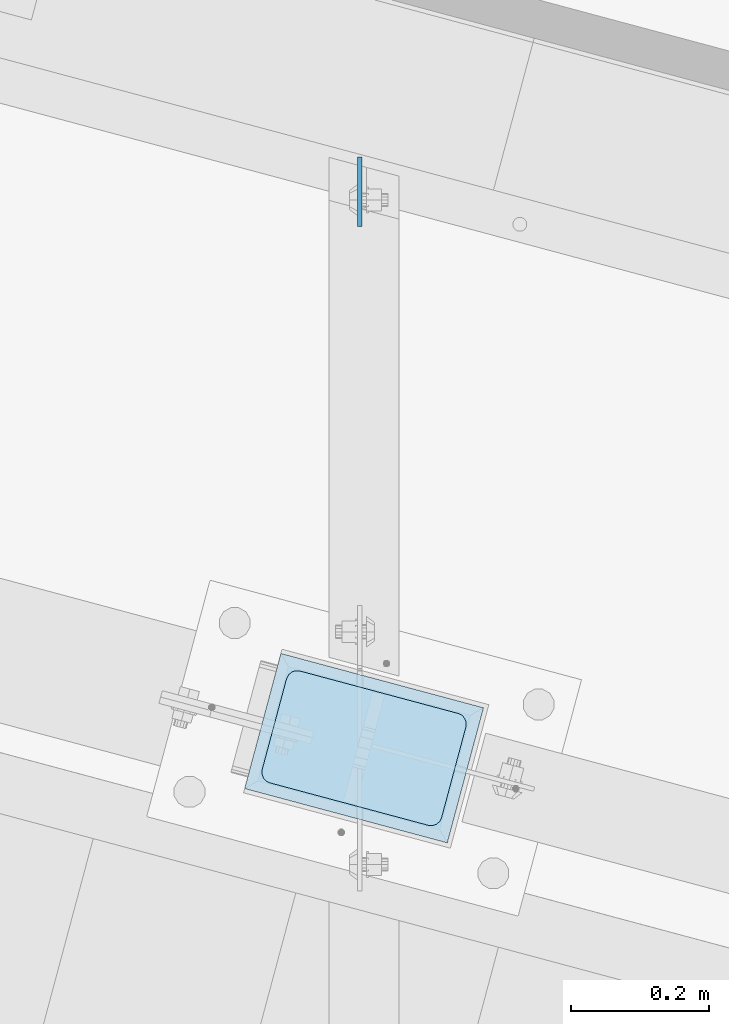
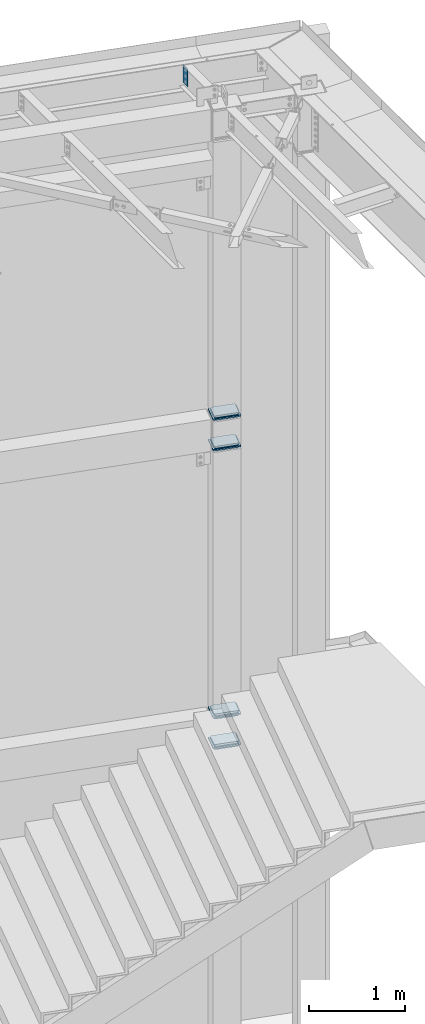
# One storey, part 1703 of 1763: 13 plates, 2 elements without a shape of their own.
"""IFC2X3 building model written with IfcOpenShell, lengths in millimetres."""

from ifc_helpers import new_model, si_unit, frame, origin_with_axes, place, context, subcontext, project, spatial, faceted_brep, material, type_object, element, aggregate, save


model = new_model("IFC2X3")

# Units and contexts
model_context = context("Model", 3, precision=1e-05, world=origin_with_axes())
body_context = subcontext(model_context, "Body", "Model", "MODEL_VIEW")
ifc_project = project(units=[si_unit("LENGTHUNIT", "METRE", prefix="MILLI"), si_unit("AREAUNIT", "SQUARE_METRE"), si_unit("VOLUMEUNIT", "CUBIC_METRE"), si_unit("MASSUNIT", "GRAM", prefix="KILO"), si_unit("TIMEUNIT", "SECOND"), si_unit("PLANEANGLEUNIT", "RADIAN"), si_unit("SOLIDANGLEUNIT", "STERADIAN"), si_unit("THERMODYNAMICTEMPERATUREUNIT", "DEGREE_CELSIUS"), si_unit("LUMINOUSINTENSITYUNIT", "LUMEN")], contexts=[model_context])

# Site, building, storey
site_placement = place(None, origin_with_axes())
site = spatial("IfcSite", under=ifc_project, at=site_placement, CompositionType="ELEMENT")
building_placement = place(site_placement, origin_with_axes())
building = spatial("IfcBuilding", under=site, at=building_placement, Name="Undefined", CompositionType="ELEMENT")
storey_placement = place(building_placement, origin_with_axes())
storey = spatial("IfcBuildingStorey", under=building, at=storey_placement, Name="Undefined", CompositionType="ELEMENT", Elevation=0.0)

# Assembly, plates
assembly_1_placement = place(storey_placement, origin_with_axes())
assembly_1 = element("IfcElementAssembly", 1, at=assembly_1_placement, inside=storey, Name="COLUMN", AssemblyPlace="NOTDEFINED", PredefinedType="RIGID_FRAME")
ifc_material_1 = material(Name="STEEL/A36")
plate_type_1 = type_object("IfcPlateType", PredefinedType="NOTDEFINED")
plate_1_placement = place(assembly_1_placement, frame((-22654.8919697089, 62208.7169412985, 8496.3), z_axis=(0.965913267114843, -0.258865912030785, 0.0), x_axis=(-0.258865912030778, -0.965913267114844, 3.00823476209188e-08)))
plate_1 = element("IfcPlate", 2, at=plate_1_placement, type_object=plate_type_1, material=ifc_material_1, Name="PLATE", context=body_context, shape_type="Brep", body=[
    faceted_brep([(-2.18278728425503e-11, -12.7000000000007, 15.875), (-1.67347025126219e-10, -12.7000000000007, 253.999999999985), (-1.67347025126219e-10, 12.7000000000007, 253.999999999985), (-2.18278728425503e-11, 12.7000000000007, 15.875), (1.20841242121242, -12.7000000000007, 260.075099488779), (1.20841242121242, 12.7000000000007, 260.075099488779), (4.649679848495, -12.7000000000007, 265.225320151323), (4.649679848495, 12.7000000000007, 265.225320151323), (9.79990051103232, -12.7000000000007, 268.666587578606), (9.79990051103232, 12.7000000000007, 268.666587578606), (15.8749999998181, -12.7000000000007, 269.874999999993), (15.8749999998181, 12.7000000000007, 269.874999999993), (152.400009155084, -12.7000000000007, 269.875000000073), (152.400009155084, 12.7000000000007, 269.875000000073), (158.475108643877, -12.7000000000007, 268.6665875787), (158.475108643877, 12.7000000000007, 268.6665875787), (163.625329306422, -12.7000000000007, 265.225320151425), (163.625329306422, 12.7000000000007, 265.225320151425), (167.066596733705, -12.7000000000007, 260.07509948888), (167.066596733705, 12.7000000000007, 260.07509948888), (168.275009155092, -12.7000000000007, 254.000000000087), (168.275009155092, 12.7000000000007, 254.000000000087), (168.275009155237, -12.7000000000007, 15.8750000001019), (168.275009155237, 12.7000000000007, 15.8750000001019), (167.066596733865, -12.7000000000007, 9.79990051130881), (167.066596733865, 12.7000000000007, 9.79990051130881), (163.625329306582, -12.7000000000007, 4.64967984876421), (163.625329306582, 12.7000000000007, 4.64967984876421), (158.475108644045, -12.7000000000007, 1.20841242148163), (158.475108644045, 12.7000000000007, 1.20841242148163), (152.400000000001, -12.6999998092651, 0.0), (152.400000000001, 12.6999998092651, 0.0), (15.8749999999854, -12.7000000000007, 0.0), (15.8749999999854, 12.7000000000007, 0.0), (9.79990051119239, -12.7000000000007, 1.20841242137976), (9.79990051119239, 12.7000000000007, 1.20841242137976), (4.64967984864779, -12.7000000000007, 4.64967984866234), (4.64967984864779, 12.7000000000007, 4.64967984866234), (1.20841242136521, -12.7000000000007, 9.79990051119967), (1.20841242136521, 12.7000000000007, 9.79990051119967)], [[[0, 1, 2, 3]], [[1, 4, 5, 2]], [[4, 6, 7, 5]], [[6, 8, 9, 7]], [[8, 10, 11, 9]], [[10, 12, 13, 11]], [[12, 14, 15, 13]], [[14, 16, 17, 15]], [[16, 18, 19, 17]], [[18, 20, 21, 19]], [[20, 22, 23, 21]], [[22, 24, 25, 23]], [[24, 26, 27, 25]], [[26, 28, 29, 27]], [[28, 30, 31, 29]], [[30, 32, 33, 31]], [[32, 34, 35, 33]], [[34, 36, 37, 35]], [[36, 38, 39, 37]], [[38, 0, 3, 39]], [[5, 7, 9, 11, 13, 15, 17, 19, 21, 23, 25, 27, 29, 31, 33, 35, 37, 39, 3, 2]], [[38, 36, 34, 32, 30, 28, 26, 24, 22, 20, 18, 16, 14, 12, 10, 8, 6, 4, 1, 0]]]),
])
plate_2_placement = place(assembly_1_placement, frame((-22654.8919697462, 62208.7169413085, 8455.025), z_axis=(0.965913267114843, -0.258865912030785, 0.0), x_axis=(-0.258865912030778, -0.965913267114844, 3.00823476209188e-08)))
plate_2 = element("IfcPlate", 3, at=plate_2_placement, type_object=plate_type_1, material=ifc_material_1, Name="PLATE", context=body_context, shape_type="Brep", body=[
    faceted_brep([(-2.18278728425503e-11, -12.7000000000007, 15.875), (-1.67347025126219e-10, -12.7000000000007, 253.999999999985), (-1.67347025126219e-10, 12.7000000000007, 253.999999999985), (-2.18278728425503e-11, 12.7000000000007, 15.875), (1.20841242121242, -12.7000000000007, 260.075099488779), (1.20841242121242, 12.7000000000007, 260.075099488779), (4.649679848495, -12.7000000000007, 265.225320151323), (4.649679848495, 12.7000000000007, 265.225320151323), (9.79990051103232, -12.7000000000007, 268.666587578606), (9.79990051103232, 12.7000000000007, 268.666587578606), (15.8749999998181, -12.7000000000007, 269.874999999993), (15.8749999998181, 12.7000000000007, 269.874999999993), (152.400009155084, -12.7000000000007, 269.875000000073), (152.400009155084, 12.7000000000007, 269.875000000073), (158.475108643877, -12.7000000000007, 268.6665875787), (158.475108643877, 12.7000000000007, 268.6665875787), (163.625329306422, -12.7000000000007, 265.225320151425), (163.625329306422, 12.7000000000007, 265.225320151425), (167.066596733705, -12.7000000000007, 260.07509948888), (167.066596733705, 12.7000000000007, 260.07509948888), (168.275009155092, -12.7000000000007, 254.000000000087), (168.275009155092, 12.7000000000007, 254.000000000087), (168.275009155237, -12.7000000000007, 15.8750000001019), (168.275009155237, 12.7000000000007, 15.8750000001019), (167.066596733865, -12.7000000000007, 9.79990051130881), (167.066596733865, 12.7000000000007, 9.79990051130881), (163.625329306582, -12.7000000000007, 4.64967984876421), (163.625329306582, 12.7000000000007, 4.64967984876421), (158.475108644045, -12.7000000000007, 1.20841242148163), (158.475108644045, 12.7000000000007, 1.20841242148163), (152.400000000001, -12.6999998092651, 0.0), (152.400000000001, 12.6999998092651, 0.0), (15.8749999999854, -12.7000000000007, 0.0), (15.8749999999854, 12.7000000000007, 0.0), (9.79990051119239, -12.7000000000007, 1.20841242137976), (9.79990051119239, 12.7000000000007, 1.20841242137976), (4.64967984864779, -12.7000000000007, 4.64967984866234), (4.64967984864779, 12.7000000000007, 4.64967984866234), (1.20841242136521, -12.7000000000007, 9.79990051119967), (1.20841242136521, 12.7000000000007, 9.79990051119967)], [[[0, 1, 2, 3]], [[1, 4, 5, 2]], [[4, 6, 7, 5]], [[6, 8, 9, 7]], [[8, 10, 11, 9]], [[10, 12, 13, 11]], [[12, 14, 15, 13]], [[14, 16, 17, 15]], [[16, 18, 19, 17]], [[18, 20, 21, 19]], [[20, 22, 23, 21]], [[22, 24, 25, 23]], [[24, 26, 27, 25]], [[26, 28, 29, 27]], [[28, 30, 31, 29]], [[30, 32, 33, 31]], [[32, 34, 35, 33]], [[34, 36, 37, 35]], [[36, 38, 39, 37]], [[38, 0, 3, 39]], [[5, 7, 9, 11, 13, 15, 17, 19, 21, 23, 25, 27, 29, 31, 33, 35, 37, 39, 3, 2]], [[38, 36, 34, 32, 30, 28, 26, 24, 22, 20, 18, 16, 14, 12, 10, 8, 6, 4, 1, 0]]]),
])
plate_3_placement = place(assembly_1_placement, frame((-22654.8919697834, 62208.7169413185, 8105.775), z_axis=(0.965913267114843, -0.258865912030785, 0.0), x_axis=(-0.258865912030778, -0.965913267114844, 3.00823476209188e-08)))
plate_3 = element("IfcPlate", 4, at=plate_3_placement, type_object=plate_type_1, material=ifc_material_1, Name="PLATE", context=body_context, shape_type="Brep", body=[
    faceted_brep([(-2.18278728425503e-11, -12.7000000000007, 15.875), (-1.67347025126219e-10, -12.7000000000007, 253.999999999985), (-1.67347025126219e-10, 12.7000000000007, 253.999999999985), (-2.18278728425503e-11, 12.7000000000007, 15.875), (1.20841242121242, -12.7000000000007, 260.075099488779), (1.20841242121242, 12.7000000000007, 260.075099488779), (4.649679848495, -12.7000000000007, 265.225320151323), (4.649679848495, 12.7000000000007, 265.225320151323), (9.79990051103232, -12.7000000000007, 268.666587578606), (9.79990051103232, 12.7000000000007, 268.666587578606), (15.8749999998181, -12.7000000000007, 269.874999999993), (15.8749999998181, 12.7000000000007, 269.874999999993), (152.400009155084, -12.7000000000007, 269.875000000073), (152.400009155084, 12.7000000000007, 269.875000000073), (158.475108643877, -12.7000000000007, 268.6665875787), (158.475108643877, 12.7000000000007, 268.6665875787), (163.625329306422, -12.7000000000007, 265.225320151425), (163.625329306422, 12.7000000000007, 265.225320151425), (167.066596733705, -12.7000000000007, 260.07509948888), (167.066596733705, 12.7000000000007, 260.07509948888), (168.275009155092, -12.7000000000007, 254.000000000087), (168.275009155092, 12.7000000000007, 254.000000000087), (168.275009155237, -12.7000000000007, 15.8750000001019), (168.275009155237, 12.7000000000007, 15.8750000001019), (167.066596733865, -12.7000000000007, 9.79990051130881), (167.066596733865, 12.7000000000007, 9.79990051130881), (163.625329306582, -12.7000000000007, 4.64967984876421), (163.625329306582, 12.7000000000007, 4.64967984876421), (158.475108644045, -12.7000000000007, 1.20841242148163), (158.475108644045, 12.7000000000007, 1.20841242148163), (152.400000000001, -12.6999998092651, 0.0), (152.400000000001, 12.6999998092651, 0.0), (15.8749999999854, -12.7000000000007, 0.0), (15.8749999999854, 12.7000000000007, 0.0), (9.79990051119239, -12.7000000000007, 1.20841242137976), (9.79990051119239, 12.7000000000007, 1.20841242137976), (4.64967984864779, -12.7000000000007, 4.64967984866234), (4.64967984864779, 12.7000000000007, 4.64967984866234), (1.20841242136521, -12.7000000000007, 9.79990051119967), (1.20841242136521, 12.7000000000007, 9.79990051119967)], [[[0, 1, 2, 3]], [[1, 4, 5, 2]], [[4, 6, 7, 5]], [[6, 8, 9, 7]], [[8, 10, 11, 9]], [[10, 12, 13, 11]], [[12, 14, 15, 13]], [[14, 16, 17, 15]], [[16, 18, 19, 17]], [[18, 20, 21, 19]], [[20, 22, 23, 21]], [[22, 24, 25, 23]], [[24, 26, 27, 25]], [[26, 28, 29, 27]], [[28, 30, 31, 29]], [[30, 32, 33, 31]], [[32, 34, 35, 33]], [[34, 36, 37, 35]], [[36, 38, 39, 37]], [[38, 0, 3, 39]], [[5, 7, 9, 11, 13, 15, 17, 19, 21, 23, 25, 27, 29, 31, 33, 35, 37, 39, 3, 2]], [[38, 36, 34, 32, 30, 28, 26, 24, 22, 20, 18, 16, 14, 12, 10, 8, 6, 4, 1, 0]]]),
])
plate_4_placement = place(assembly_1_placement, frame((-22654.8919698207, 62208.7169413285, 8064.5), z_axis=(0.965913267114843, -0.258865912030785, 0.0), x_axis=(-0.258865912030778, -0.965913267114844, 3.00823476209188e-08)))
plate_4 = element("IfcPlate", 5, at=plate_4_placement, type_object=plate_type_1, material=ifc_material_1, Name="PLATE", context=body_context, shape_type="Brep", body=[
    faceted_brep([(-2.18278728425503e-11, -12.7000000000007, 15.875), (-1.67347025126219e-10, -12.7000000000007, 253.999999999985), (-1.67347025126219e-10, 12.7000000000007, 253.999999999985), (-2.18278728425503e-11, 12.7000000000007, 15.875), (1.20841242121242, -12.7000000000007, 260.075099488779), (1.20841242121242, 12.7000000000007, 260.075099488779), (4.649679848495, -12.7000000000007, 265.225320151323), (4.649679848495, 12.7000000000007, 265.225320151323), (9.79990051103232, -12.7000000000007, 268.666587578606), (9.79990051103232, 12.7000000000007, 268.666587578606), (15.8749999998181, -12.7000000000007, 269.874999999993), (15.8749999998181, 12.7000000000007, 269.874999999993), (152.400009155084, -12.7000000000007, 269.875000000073), (152.400009155084, 12.7000000000007, 269.875000000073), (158.475108643877, -12.7000000000007, 268.6665875787), (158.475108643877, 12.7000000000007, 268.6665875787), (163.625329306422, -12.7000000000007, 265.225320151425), (163.625329306422, 12.7000000000007, 265.225320151425), (167.066596733705, -12.7000000000007, 260.07509948888), (167.066596733705, 12.7000000000007, 260.07509948888), (168.275009155092, -12.7000000000007, 254.000000000087), (168.275009155092, 12.7000000000007, 254.000000000087), (168.275009155237, -12.7000000000007, 15.8750000001019), (168.275009155237, 12.7000000000007, 15.8750000001019), (167.066596733865, -12.7000000000007, 9.79990051130881), (167.066596733865, 12.7000000000007, 9.79990051130881), (163.625329306582, -12.7000000000007, 4.64967984876421), (163.625329306582, 12.7000000000007, 4.64967984876421), (158.475108644045, -12.7000000000007, 1.20841242148163), (158.475108644045, 12.7000000000007, 1.20841242148163), (152.400000000001, -12.6999998092651, 0.0), (152.400000000001, 12.6999998092651, 0.0), (15.8749999999854, -12.7000000000007, 0.0), (15.8749999999854, 12.7000000000007, 0.0), (9.79990051119239, -12.7000000000007, 1.20841242137976), (9.79990051119239, 12.7000000000007, 1.20841242137976), (4.64967984864779, -12.7000000000007, 4.64967984866234), (4.64967984864779, 12.7000000000007, 4.64967984866234), (1.20841242136521, -12.7000000000007, 9.79990051119967), (1.20841242136521, 12.7000000000007, 9.79990051119967)], [[[0, 1, 2, 3]], [[1, 4, 5, 2]], [[4, 6, 7, 5]], [[6, 8, 9, 7]], [[8, 10, 11, 9]], [[10, 12, 13, 11]], [[12, 14, 15, 13]], [[14, 16, 17, 15]], [[16, 18, 19, 17]], [[18, 20, 21, 19]], [[20, 22, 23, 21]], [[22, 24, 25, 23]], [[24, 26, 27, 25]], [[26, 28, 29, 27]], [[28, 30, 31, 29]], [[30, 32, 33, 31]], [[32, 34, 35, 33]], [[34, 36, 37, 35]], [[36, 38, 39, 37]], [[38, 0, 3, 39]], [[5, 7, 9, 11, 13, 15, 17, 19, 21, 23, 25, 27, 29, 31, 33, 35, 37, 39, 3, 2]], [[38, 36, 34, 32, 30, 28, 26, 24, 22, 20, 18, 16, 14, 12, 10, 8, 6, 4, 1, 0]]]),
])
plate_5_placement = place(assembly_1_placement, frame((-22654.8919697089, 62208.7169412985, 4686.3), z_axis=(0.965913267114843, -0.258865912030785, 0.0), x_axis=(-0.258865912030778, -0.965913267114844, 3.00823476209188e-08)))
plate_5 = element("IfcPlate", 6, at=plate_5_placement, type_object=plate_type_1, material=ifc_material_1, Name="PLATE", context=body_context, shape_type="Brep", body=[
    faceted_brep([(-2.18278728425503e-11, -12.7000000000007, 15.875), (-1.67347025126219e-10, -12.7000000000007, 253.999999999985), (-1.67347025126219e-10, 12.7000000000007, 253.999999999985), (-2.18278728425503e-11, 12.7000000000007, 15.875), (1.20841242121242, -12.7000000000007, 260.075099488779), (1.20841242121242, 12.7000000000007, 260.075099488779), (4.649679848495, -12.7000000000007, 265.225320151323), (4.649679848495, 12.7000000000007, 265.225320151323), (9.79990051103232, -12.7000000000007, 268.666587578606), (9.79990051103232, 12.7000000000007, 268.666587578606), (15.8749999998181, -12.7000000000007, 269.874999999993), (15.8749999998181, 12.7000000000007, 269.874999999993), (152.400009155084, -12.7000000000007, 269.875000000073), (152.400009155084, 12.7000000000007, 269.875000000073), (158.475108643877, -12.7000000000007, 268.6665875787), (158.475108643877, 12.7000000000007, 268.6665875787), (163.625329306422, -12.7000000000007, 265.225320151425), (163.625329306422, 12.7000000000007, 265.225320151425), (167.066596733705, -12.7000000000007, 260.07509948888), (167.066596733705, 12.7000000000007, 260.07509948888), (168.275009155092, -12.7000000000007, 254.000000000087), (168.275009155092, 12.7000000000007, 254.000000000087), (168.275009155237, -12.7000000000007, 15.8750000001019), (168.275009155237, 12.7000000000007, 15.8750000001019), (167.066596733865, -12.7000000000007, 9.79990051130881), (167.066596733865, 12.7000000000007, 9.79990051130881), (163.625329306582, -12.7000000000007, 4.64967984876421), (163.625329306582, 12.7000000000007, 4.64967984876421), (158.475108644045, -12.7000000000007, 1.20841242148163), (158.475108644045, 12.7000000000007, 1.20841242148163), (152.400000000001, -12.6999998092651, 0.0), (152.400000000001, 12.6999998092651, 0.0), (15.8749999999854, -12.7000000000007, 0.0), (15.8749999999854, 12.7000000000007, 0.0), (9.79990051119239, -12.7000000000007, 1.20841242137976), (9.79990051119239, 12.7000000000007, 1.20841242137976), (4.64967984864779, -12.7000000000007, 4.64967984866234), (4.64967984864779, 12.7000000000007, 4.64967984866234), (1.20841242136521, -12.7000000000007, 9.79990051119967), (1.20841242136521, 12.7000000000007, 9.79990051119967)], [[[0, 1, 2, 3]], [[1, 4, 5, 2]], [[4, 6, 7, 5]], [[6, 8, 9, 7]], [[8, 10, 11, 9]], [[10, 12, 13, 11]], [[12, 14, 15, 13]], [[14, 16, 17, 15]], [[16, 18, 19, 17]], [[18, 20, 21, 19]], [[20, 22, 23, 21]], [[22, 24, 25, 23]], [[24, 26, 27, 25]], [[26, 28, 29, 27]], [[28, 30, 31, 29]], [[30, 32, 33, 31]], [[32, 34, 35, 33]], [[34, 36, 37, 35]], [[36, 38, 39, 37]], [[38, 0, 3, 39]], [[5, 7, 9, 11, 13, 15, 17, 19, 21, 23, 25, 27, 29, 31, 33, 35, 37, 39, 3, 2]], [[38, 36, 34, 32, 30, 28, 26, 24, 22, 20, 18, 16, 14, 12, 10, 8, 6, 4, 1, 0]]]),
])
plate_6_placement = place(assembly_1_placement, frame((-22654.8919697462, 62208.7169413085, 4645.025), z_axis=(0.965913267114843, -0.258865912030785, 0.0), x_axis=(-0.258865912030778, -0.965913267114844, 3.00823476209188e-08)))
plate_6 = element("IfcPlate", 7, at=plate_6_placement, type_object=plate_type_1, material=ifc_material_1, Name="PLATE", context=body_context, shape_type="Brep", body=[
    faceted_brep([(-2.18278728425503e-11, -12.7000000000007, 15.875), (-1.67347025126219e-10, -12.7000000000007, 253.999999999985), (-1.67347025126219e-10, 12.7000000000007, 253.999999999985), (-2.18278728425503e-11, 12.7000000000007, 15.875), (1.20841242121242, -12.7000000000007, 260.075099488779), (1.20841242121242, 12.7000000000007, 260.075099488779), (4.649679848495, -12.7000000000007, 265.225320151323), (4.649679848495, 12.7000000000007, 265.225320151323), (9.79990051103232, -12.7000000000007, 268.666587578606), (9.79990051103232, 12.7000000000007, 268.666587578606), (15.8749999998181, -12.7000000000007, 269.874999999993), (15.8749999998181, 12.7000000000007, 269.874999999993), (152.400009155084, -12.7000000000007, 269.875000000073), (152.400009155084, 12.7000000000007, 269.875000000073), (158.475108643877, -12.7000000000007, 268.6665875787), (158.475108643877, 12.7000000000007, 268.6665875787), (163.625329306422, -12.7000000000007, 265.225320151425), (163.625329306422, 12.7000000000007, 265.225320151425), (167.066596733705, -12.7000000000007, 260.07509948888), (167.066596733705, 12.7000000000007, 260.07509948888), (168.275009155092, -12.7000000000007, 254.000000000087), (168.275009155092, 12.7000000000007, 254.000000000087), (168.275009155237, -12.7000000000007, 15.8750000001019), (168.275009155237, 12.7000000000007, 15.8750000001019), (167.066596733865, -12.7000000000007, 9.79990051130881), (167.066596733865, 12.7000000000007, 9.79990051130881), (163.625329306582, -12.7000000000007, 4.64967984876421), (163.625329306582, 12.7000000000007, 4.64967984876421), (158.475108644045, -12.7000000000007, 1.20841242148163), (158.475108644045, 12.7000000000007, 1.20841242148163), (152.400000000001, -12.6999998092651, 0.0), (152.400000000001, 12.6999998092651, 0.0), (15.8749999999854, -12.7000000000007, 0.0), (15.8749999999854, 12.7000000000007, 0.0), (9.79990051119239, -12.7000000000007, 1.20841242137976), (9.79990051119239, 12.7000000000007, 1.20841242137976), (4.64967984864779, -12.7000000000007, 4.64967984866234), (4.64967984864779, 12.7000000000007, 4.64967984866234), (1.20841242136521, -12.7000000000007, 9.79990051119967), (1.20841242136521, 12.7000000000007, 9.79990051119967)], [[[0, 1, 2, 3]], [[1, 4, 5, 2]], [[4, 6, 7, 5]], [[6, 8, 9, 7]], [[8, 10, 11, 9]], [[10, 12, 13, 11]], [[12, 14, 15, 13]], [[14, 16, 17, 15]], [[16, 18, 19, 17]], [[18, 20, 21, 19]], [[20, 22, 23, 21]], [[22, 24, 25, 23]], [[24, 26, 27, 25]], [[26, 28, 29, 27]], [[28, 30, 31, 29]], [[30, 32, 33, 31]], [[32, 34, 35, 33]], [[34, 36, 37, 35]], [[36, 38, 39, 37]], [[38, 0, 3, 39]], [[5, 7, 9, 11, 13, 15, 17, 19, 21, 23, 25, 27, 29, 31, 33, 35, 37, 39, 3, 2]], [[38, 36, 34, 32, 30, 28, 26, 24, 22, 20, 18, 16, 14, 12, 10, 8, 6, 4, 1, 0]]]),
])
plate_7_placement = place(assembly_1_placement, frame((-22654.8919697834, 62208.7169413185, 4295.775), z_axis=(0.965913267114843, -0.258865912030785, 0.0), x_axis=(-0.258865912030778, -0.965913267114844, 3.00823476209188e-08)))
plate_7 = element("IfcPlate", 8, at=plate_7_placement, type_object=plate_type_1, material=ifc_material_1, Name="PLATE", context=body_context, shape_type="Brep", body=[
    faceted_brep([(-2.18278728425503e-11, -12.7000000000007, 15.875), (-1.67347025126219e-10, -12.7000000000007, 253.999999999985), (-1.67347025126219e-10, 12.7000000000007, 253.999999999985), (-2.18278728425503e-11, 12.7000000000007, 15.875), (1.20841242121242, -12.7000000000007, 260.075099488779), (1.20841242121242, 12.7000000000007, 260.075099488779), (4.649679848495, -12.7000000000007, 265.225320151323), (4.649679848495, 12.7000000000007, 265.225320151323), (9.79990051103232, -12.7000000000007, 268.666587578606), (9.79990051103232, 12.7000000000007, 268.666587578606), (15.8749999998181, -12.7000000000007, 269.874999999993), (15.8749999998181, 12.7000000000007, 269.874999999993), (152.400009155084, -12.7000000000007, 269.875000000073), (152.400009155084, 12.7000000000007, 269.875000000073), (158.475108643877, -12.7000000000007, 268.6665875787), (158.475108643877, 12.7000000000007, 268.6665875787), (163.625329306422, -12.7000000000007, 265.225320151425), (163.625329306422, 12.7000000000007, 265.225320151425), (167.066596733705, -12.7000000000007, 260.07509948888), (167.066596733705, 12.7000000000007, 260.07509948888), (168.275009155092, -12.7000000000007, 254.000000000087), (168.275009155092, 12.7000000000007, 254.000000000087), (168.275009155237, -12.7000000000007, 15.8750000001019), (168.275009155237, 12.7000000000007, 15.8750000001019), (167.066596733865, -12.7000000000007, 9.79990051130881), (167.066596733865, 12.7000000000007, 9.79990051130881), (163.625329306582, -12.7000000000007, 4.64967984876421), (163.625329306582, 12.7000000000007, 4.64967984876421), (158.475108644045, -12.7000000000007, 1.20841242148163), (158.475108644045, 12.7000000000007, 1.20841242148163), (152.400000000001, -12.6999998092651, 0.0), (152.400000000001, 12.6999998092651, 0.0), (15.8749999999854, -12.7000000000007, 0.0), (15.8749999999854, 12.7000000000007, 0.0), (9.79990051119239, -12.7000000000007, 1.20841242137976), (9.79990051119239, 12.7000000000007, 1.20841242137976), (4.64967984864779, -12.7000000000007, 4.64967984866234), (4.64967984864779, 12.7000000000007, 4.64967984866234), (1.20841242136521, -12.7000000000007, 9.79990051119967), (1.20841242136521, 12.7000000000007, 9.79990051119967)], [[[0, 1, 2, 3]], [[1, 4, 5, 2]], [[4, 6, 7, 5]], [[6, 8, 9, 7]], [[8, 10, 11, 9]], [[10, 12, 13, 11]], [[12, 14, 15, 13]], [[14, 16, 17, 15]], [[16, 18, 19, 17]], [[18, 20, 21, 19]], [[20, 22, 23, 21]], [[22, 24, 25, 23]], [[24, 26, 27, 25]], [[26, 28, 29, 27]], [[28, 30, 31, 29]], [[30, 32, 33, 31]], [[32, 34, 35, 33]], [[34, 36, 37, 35]], [[36, 38, 39, 37]], [[38, 0, 3, 39]], [[5, 7, 9, 11, 13, 15, 17, 19, 21, 23, 25, 27, 29, 31, 33, 35, 37, 39, 3, 2]], [[38, 36, 34, 32, 30, 28, 26, 24, 22, 20, 18, 16, 14, 12, 10, 8, 6, 4, 1, 0]]]),
])
plate_8_placement = place(assembly_1_placement, frame((-22654.8919698207, 62208.7169413285, 4254.5), z_axis=(0.965913267114843, -0.258865912030785, 0.0), x_axis=(-0.258865912030778, -0.965913267114844, 3.00823476209188e-08)))
plate_8 = element("IfcPlate", 9, at=plate_8_placement, type_object=plate_type_1, material=ifc_material_1, Name="PLATE", context=body_context, shape_type="Brep", body=[
    faceted_brep([(-2.18278728425503e-11, -12.7000000000007, 15.875), (-1.67347025126219e-10, -12.7000000000007, 253.999999999985), (-1.67347025126219e-10, 12.7000000000007, 253.999999999985), (-2.18278728425503e-11, 12.7000000000007, 15.875), (1.20841242121242, -12.7000000000007, 260.075099488779), (1.20841242121242, 12.7000000000007, 260.075099488779), (4.649679848495, -12.7000000000007, 265.225320151323), (4.649679848495, 12.7000000000007, 265.225320151323), (9.79990051103232, -12.7000000000007, 268.666587578606), (9.79990051103232, 12.7000000000007, 268.666587578606), (15.8749999998181, -12.7000000000007, 269.874999999993), (15.8749999998181, 12.7000000000007, 269.874999999993), (152.400009155084, -12.7000000000007, 269.875000000073), (152.400009155084, 12.7000000000007, 269.875000000073), (158.475108643877, -12.7000000000007, 268.6665875787), (158.475108643877, 12.7000000000007, 268.6665875787), (163.625329306422, -12.7000000000007, 265.225320151425), (163.625329306422, 12.7000000000007, 265.225320151425), (167.066596733705, -12.7000000000007, 260.07509948888), (167.066596733705, 12.7000000000007, 260.07509948888), (168.275009155092, -12.7000000000007, 254.000000000087), (168.275009155092, 12.7000000000007, 254.000000000087), (168.275009155237, -12.7000000000007, 15.8750000001019), (168.275009155237, 12.7000000000007, 15.8750000001019), (167.066596733865, -12.7000000000007, 9.79990051130881), (167.066596733865, 12.7000000000007, 9.79990051130881), (163.625329306582, -12.7000000000007, 4.64967984876421), (163.625329306582, 12.7000000000007, 4.64967984876421), (158.475108644045, -12.7000000000007, 1.20841242148163), (158.475108644045, 12.7000000000007, 1.20841242148163), (152.400000000001, -12.6999998092651, 0.0), (152.400000000001, 12.6999998092651, 0.0), (15.8749999999854, -12.7000000000007, 0.0), (15.8749999999854, 12.7000000000007, 0.0), (9.79990051119239, -12.7000000000007, 1.20841242137976), (9.79990051119239, 12.7000000000007, 1.20841242137976), (4.64967984864779, -12.7000000000007, 4.64967984866234), (4.64967984864779, 12.7000000000007, 4.64967984866234), (1.20841242136521, -12.7000000000007, 9.79990051119967), (1.20841242136521, 12.7000000000007, 9.79990051119967)], [[[0, 1, 2, 3]], [[1, 4, 5, 2]], [[4, 6, 7, 5]], [[6, 8, 9, 7]], [[8, 10, 11, 9]], [[10, 12, 13, 11]], [[12, 14, 15, 13]], [[14, 16, 17, 15]], [[16, 18, 19, 17]], [[18, 20, 21, 19]], [[20, 22, 23, 21]], [[22, 24, 25, 23]], [[24, 26, 27, 25]], [[26, 28, 29, 27]], [[28, 30, 31, 29]], [[30, 32, 33, 31]], [[32, 34, 35, 33]], [[34, 36, 37, 35]], [[36, 38, 39, 37]], [[38, 0, 3, 39]], [[5, 7, 9, 11, 13, 15, 17, 19, 21, 23, 25, 27, 29, 31, 33, 35, 37, 39, 3, 2]], [[38, 36, 34, 32, 30, 28, 26, 24, 22, 20, 18, 16, 14, 12, 10, 8, 6, 4, 1, 0]]]),
])
ifc_material_2 = material(Name="STEEL/A572-50")
plate_type_2 = type_object("IfcPlateType", PredefinedType="NOTDEFINED")
plate_9_placement = place(assembly_1_placement, frame((-22667.2292549365, 62230.1020943703, 8475.6625), z_axis=(0.965913267114843, -0.258865912030785, 0.0), x_axis=(-0.258865912030778, -0.965913267114844, 3.00823476209188e-08)))
plate_9 = element("IfcPlate", 10, at=plate_9_placement, type_object=plate_type_2, material=ifc_material_2, Name="PLATE", context=body_context, shape_type="Brep", body=[
    faceted_brep([(-7.27595761418343e-12, -7.9375, 0.0), (-1.96450855582952e-10, -7.9375, 304.799987792954), (-1.96450855582952e-10, 7.9375, 304.799987792954), (-7.27595761418343e-12, 7.9375, 0.0), (203.199996948031, -7.9375, 304.799987793078), (203.199996948031, 7.9375, 304.799987793078), (203.199996948228, -7.9375, 1.30967237055302e-10), (203.199996948228, 7.9375, 1.30967237055302e-10)], [[[0, 1, 2, 3]], [[1, 4, 5, 2]], [[4, 6, 7, 5]], [[6, 0, 3, 7]], [[5, 7, 3, 2]], [[6, 4, 1, 0]]]),
])
plate_10_placement = place(assembly_1_placement, frame((-22667.229255011, 62230.1020943903, 8085.1375), z_axis=(0.965913267114843, -0.258865912030785, 0.0), x_axis=(-0.258865912030778, -0.965913267114844, 3.00823476209188e-08)))
plate_10 = element("IfcPlate", 11, at=plate_10_placement, type_object=plate_type_2, material=ifc_material_2, Name="PLATE", context=body_context, shape_type="Brep", body=[
    faceted_brep([(-7.27595761418343e-12, -7.9375, 0.0), (-1.96450855582952e-10, -7.9375, 304.799987792954), (-1.96450855582952e-10, 7.9375, 304.799987792954), (-7.27595761418343e-12, 7.9375, 0.0), (203.199996948031, -7.9375, 304.799987793078), (203.199996948031, 7.9375, 304.799987793078), (203.199996948228, -7.9375, 1.30967237055302e-10), (203.199996948228, 7.9375, 1.30967237055302e-10)], [[[0, 1, 2, 3]], [[1, 4, 5, 2]], [[4, 6, 7, 5]], [[6, 0, 3, 7]], [[5, 7, 3, 2]], [[6, 4, 1, 0]]]),
])
plate_11_placement = place(assembly_1_placement, frame((-22667.2292549365, 62230.1020943703, 4665.6625), z_axis=(0.965913267114843, -0.258865912030785, 0.0), x_axis=(-0.258865912030778, -0.965913267114844, 3.00823476209188e-08)))
plate_11 = element("IfcPlate", 12, at=plate_11_placement, type_object=plate_type_2, material=ifc_material_2, Name="PLATE", context=body_context, shape_type="Brep", body=[
    faceted_brep([(-7.27595761418343e-12, -7.9375, 0.0), (-1.96450855582952e-10, -7.9375, 304.799987792954), (-1.96450855582952e-10, 7.9375, 304.799987792954), (-7.27595761418343e-12, 7.9375, 0.0), (203.199996948031, -7.9375, 304.799987793078), (203.199996948031, 7.9375, 304.799987793078), (203.199996948228, -7.9375, 1.30967237055302e-10), (203.199996948228, 7.9375, 1.30967237055302e-10)], [[[0, 1, 2, 3]], [[1, 4, 5, 2]], [[4, 6, 7, 5]], [[6, 0, 3, 7]], [[5, 7, 3, 2]], [[6, 4, 1, 0]]]),
])
plate_12_placement = place(assembly_1_placement, frame((-22667.229255011, 62230.1020943903, 4275.1375), z_axis=(0.965913267114843, -0.258865912030785, 0.0), x_axis=(-0.258865912030778, -0.965913267114844, 3.00823476209188e-08)))
plate_12 = element("IfcPlate", 13, at=plate_12_placement, type_object=plate_type_2, material=ifc_material_2, Name="PLATE", context=body_context, shape_type="Brep", body=[
    faceted_brep([(-7.27595761418343e-12, -7.9375, 0.0), (-1.96450855582952e-10, -7.9375, 304.799987792954), (-1.96450855582952e-10, 7.9375, 304.799987792954), (-7.27595761418343e-12, 7.9375, 0.0), (203.199996948031, -7.9375, 304.799987793078), (203.199996948031, 7.9375, 304.799987793078), (203.199996948228, -7.9375, 1.30967237055302e-10), (203.199996948228, 7.9375, 1.30967237055302e-10)], [[[0, 1, 2, 3]], [[1, 4, 5, 2]], [[4, 6, 7, 5]], [[6, 0, 3, 7]], [[5, 7, 3, 2]], [[6, 4, 1, 0]]]),
])
aggregate(assembly_1, [plate_1, plate_2, plate_9, plate_3, plate_4, plate_10, plate_5, plate_6, plate_11, plate_7, plate_8, plate_12])

# Assembly, plate
assembly_2_placement = place(storey_placement, origin_with_axes())
assembly_2 = element("IfcElementAssembly", 14, at=assembly_2_placement, inside=storey, Name="BEAM", AssemblyPlace="NOTDEFINED", PredefinedType="RIGID_FRAME")
plate_type_3 = type_object("IfcPlateType", PredefinedType="NOTDEFINED")
plate_13_placement = place(assembly_2_placement, frame((-22552.6796174638, 62951.3682883473, 12407.9), z_axis=(0.0, -1.0, 0.0), x_axis=(0.0, 0.0, -1.0)))
plate_13 = element("IfcPlate", 15, at=plate_13_placement, type_object=plate_type_3, material=ifc_material_1, Name="PLATE", context=body_context, shape_type="Brep", body=[
    faceted_brep([(1.81898940354586e-12, -3.17500000000291, 0.0), (0.0, -3.17499999982829, 100.460510253775), (0.0, 3.17500000019209, 100.460510253775), (-1.81898940354586e-12, 3.17499999997381, 0.0), (228.600006103516, -3.17499999982829, 100.460510253775), (228.600006103516, 3.17500000019209, 100.460510253775), (228.600006103516, -3.17500000001019, -7.27595761418343e-12), (228.600006103516, 3.17499999999563, -7.27595761418343e-12)], [[[0, 1, 2, 3]], [[1, 4, 5, 2]], [[4, 6, 7, 5]], [[6, 0, 3, 7]], [[5, 7, 3, 2]], [[6, 4, 1, 0]]]),
])
aggregate(assembly_2, [plate_13])

save(model, "model.ifc")
